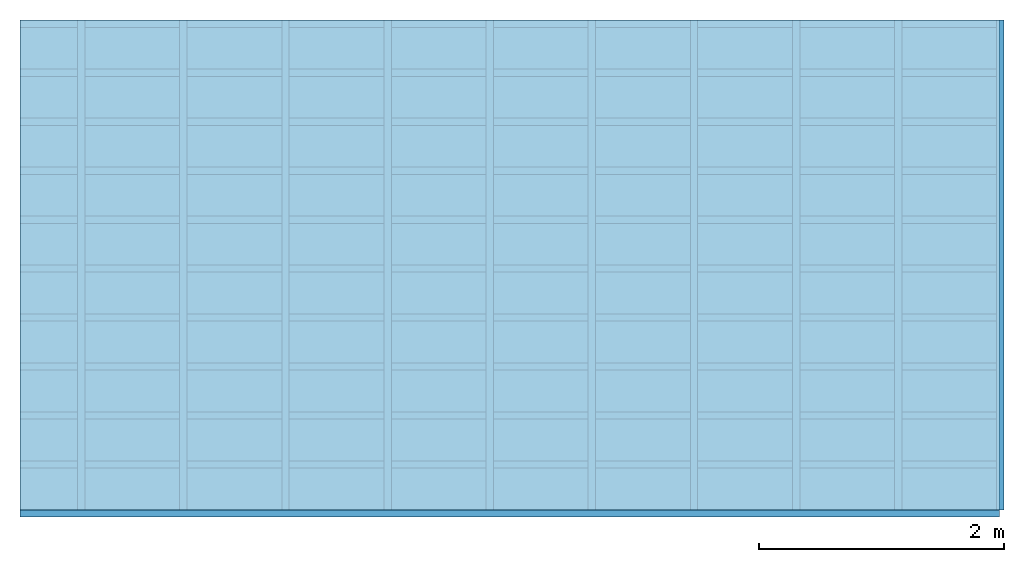
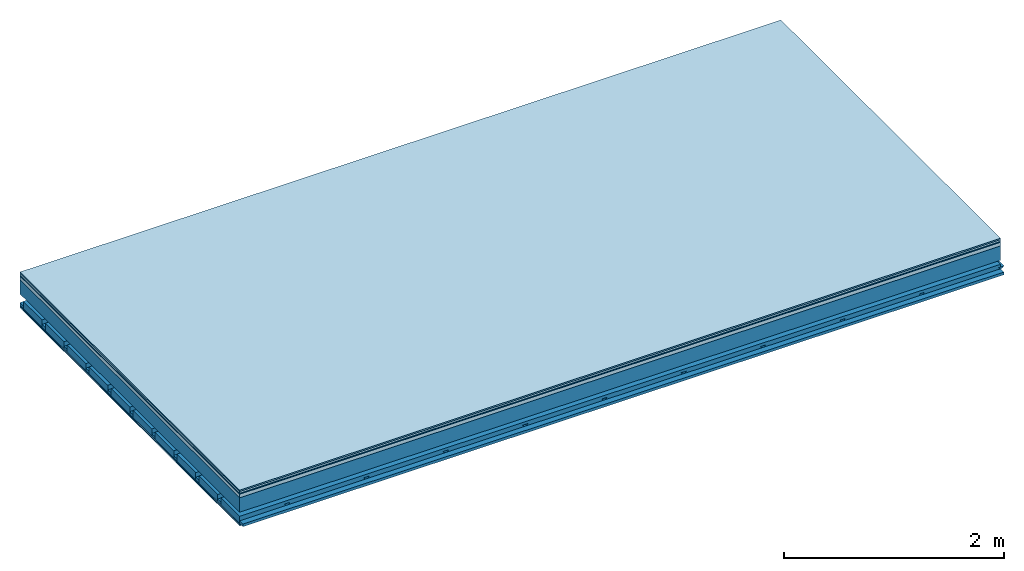
# One storey: 7 plates, 4 members, 1 element without a shape of its own.
"""IFC4 building model written with IfcOpenShell, lengths in metres."""

from ifc_helpers import new_model, si_unit, derived_unit, direction, frame, frame_2d, origin, origin_with_axes, place, context, project, spatial, polyline, rectangle, outline, extrude, material, layer, layer_set, type_object, element, aggregate, save


model = new_model("IFC4")

# Units and contexts
plan_context = context("Plan", 3, precision=1e-05, world=origin(), true_north=direction((0.0, 1.0)))
model_context = context("Model", 3, precision=1e-05, world=origin(), true_north=direction((0.0, 1.0)))
ifc_project = project(units=[si_unit("LENGTHUNIT", "METRE"), derived_unit("SOUNDPRESSUREUNIT", [(si_unit("PRESSUREUNIT", "PASCAL", prefix="MICRO"), 0)]), si_unit("ENERGYUNIT", "JOULE", prefix="MEGA"), si_unit("MASSUNIT", "GRAM", prefix="KILO"), derived_unit("THERMALTRANSMITTANCEUNIT", [(si_unit("POWERUNIT", "WATT"), 1), (si_unit("AREAUNIT", "SQUARE_METRE"), -1), (si_unit("THERMODYNAMICTEMPERATUREUNIT", "KELVIN"), -1)]), derived_unit("AREADENSITYUNIT", [(si_unit("MASSUNIT", "GRAM", prefix="KILO"), 1), (si_unit("AREAUNIT", "SQUARE_METRE"), -1)]), derived_unit("USERDEFINED", [(si_unit("ENERGYUNIT", "JOULE", prefix="MEGA"), 1), (si_unit("AREAUNIT", "SQUARE_METRE"), -1)])], contexts=[plan_context, model_context])

# Site, building, storey
site = spatial("IfcSite", under=ifc_project)
building_placement = place(None, origin())
building = spatial("IfcBuilding", under=site, at=building_placement)
storey_placement = place(building_placement, origin())
storey = spatial("IfcBuildingStorey", under=building, at=storey_placement)

# Slab, members, plates
ifc_material_1 = material(Category="11.013")
ifc_layer_1 = layer(ifc_material_1, 0.015, Name="Flooring")
ifc_material_2 = material(Category="03.007")
ifc_layer_2 = layer(ifc_material_2, 0.02, Name="On-material")
ifc_material_3 = material(Name="Wood fiber generic product", Category="10.009")
ifc_layer_3 = layer(ifc_material_3, 0.01, Name="Impact sound insulation")
ifc_material_4 = material(Name="Concrete panels", Category="02.007")
ifc_layer_4 = layer(ifc_material_4, 0.04, Name="on Supporting structure")
ifc_material_5 = material(Name="no composite action")
ifc_layer_5 = layer(ifc_material_5, 0.0, Name="Bond")
ifc_layer_6 = layer(None, 0.16, Name="Supporting structure")
ifc_layer_7 = layer(ifc_material_5, 0.0, Name="Bond")
ifc_layer_8 = layer(None, 0.095, Name="Coupling")
ifc_layer_9 = layer(None, 0.03, Name="Battens / profiles")
ifc_material_6 = material(Name="Plasterboard type A", Category="03.008")
ifc_layer_10 = layer(ifc_material_6, 0.0125, Name="Ceiling covering 1st layer")
ifc_layer_11 = layer(ifc_material_6, 0.0125, Name="Ceiling covering layer 2")
ifc_material_7 = material(Category="04.001")
ifc_layer_12 = layer(ifc_material_7, 0.003, Name="Surface / treatment")
ifc_layer_set = layer_set([ifc_layer_1, ifc_layer_2, ifc_layer_3, ifc_layer_4, ifc_layer_5, ifc_layer_6, ifc_layer_7, ifc_layer_8, ifc_layer_9, ifc_layer_10, ifc_layer_11, ifc_layer_12])
slab_type = type_object("IfcSlabType", Name="A2134", PredefinedType="NOTDEFINED", material=ifc_layer_set)
slab_placement = place(None, frame((0.0, 0.0, 0.0), z_axis=(0.0, 0.0, -1.0), x_axis=(1.0, 0.0, 0.0)))
slab = element("IfcSlab", 1, at=slab_placement, inside=storey, type_object=slab_type, material=ifc_layer_set, Name="Slab #1")
ifc_material_8 = material(Name="Solid timber panel")
member_1_placement = place(slab_placement, origin())
member_1 = element("IfcMember", 2, at=member_1_placement, material=ifc_material_8, Name="Supporting structure", context=plan_context, shape_type="SweptSolid", body=[
    extrude(rectangle(XDim=1.0, YDim=0.16, at=frame_2d((0.5, 0.08), x_axis=(1.0, 0.0))), frame((0.0, 4.0, 0.085), z_axis=(0.0, -1.0, 0.0), x_axis=(1.0, 0.0, 0.0)), (0.0, 0.0, 1.0), 4.0),
    extrude(rectangle(XDim=1.0, YDim=0.16, at=frame_2d((0.5, 0.08), x_axis=(1.0, 0.0))), frame((1.0, 4.0, 0.085), z_axis=(0.0, -1.0, 0.0), x_axis=(1.0, 0.0, 0.0)), (0.0, 0.0, 1.0), 4.0),
    extrude(rectangle(XDim=1.0, YDim=0.16, at=frame_2d((0.5, 0.08), x_axis=(1.0, 0.0))), frame((2.0, 4.0, 0.085), z_axis=(0.0, -1.0, 0.0), x_axis=(1.0, 0.0, 0.0)), (0.0, 0.0, 1.0), 4.0),
    extrude(rectangle(XDim=1.0, YDim=0.16, at=frame_2d((0.5, 0.08), x_axis=(1.0, 0.0))), frame((3.0, 4.0, 0.085), z_axis=(0.0, -1.0, 0.0), x_axis=(1.0, 0.0, 0.0)), (0.0, 0.0, 1.0), 4.0),
    extrude(rectangle(XDim=1.0, YDim=0.16, at=frame_2d((0.5, 0.08), x_axis=(1.0, 0.0))), frame((4.0, 4.0, 0.085), z_axis=(0.0, -1.0, 0.0), x_axis=(1.0, 0.0, 0.0)), (0.0, 0.0, 1.0), 4.0),
    extrude(rectangle(XDim=1.0, YDim=0.16, at=frame_2d((0.5, 0.08), x_axis=(1.0, 0.0))), frame((5.0, 4.0, 0.085), z_axis=(0.0, -1.0, 0.0), x_axis=(1.0, 0.0, 0.0)), (0.0, 0.0, 1.0), 4.0),
    extrude(rectangle(XDim=1.0, YDim=0.16, at=frame_2d((0.5, 0.08), x_axis=(1.0, 0.0))), frame((6.0, 4.0, 0.085), z_axis=(0.0, -1.0, 0.0), x_axis=(1.0, 0.0, 0.0)), (0.0, 0.0, 1.0), 4.0),
    extrude(rectangle(XDim=1.0, YDim=0.16, at=frame_2d((0.5, 0.08), x_axis=(1.0, 0.0))), frame((7.0, 4.0, 0.085), z_axis=(0.0, -1.0, 0.0), x_axis=(1.0, 0.0, 0.0)), (0.0, 0.0, 1.0), 4.0),
])
ifc_material_9 = material()
member_2_placement = place(slab_placement, origin())
member_2 = element("IfcMember", 3, at=member_2_placement, material=ifc_material_9, Name="Coupling", context=plan_context, shape_type="SweptSolid", body=[
    extrude(outline(polyline([(0.0, 0.0), (0.06, 0.0), (0.04, 0.02), (0.02, 0.02), (0.0, 0.0)])), frame((0.47, 4.0, 0.32), z_axis=(0.0, -1.0, 0.0), x_axis=(1.0, 0.0, 0.0)), (0.0, 0.0, 1.0), 4.0),
    extrude(outline(polyline([(0.0, 0.0), (0.06, 0.0), (0.04, 0.02), (0.02, 0.02), (0.0, 0.0)])), frame((1.304, 4.0, 0.32), z_axis=(0.0, -1.0, 0.0), x_axis=(1.0, 0.0, 0.0)), (0.0, 0.0, 1.0), 4.0),
    extrude(outline(polyline([(0.0, 0.0), (0.06, 0.0), (0.04, 0.02), (0.02, 0.02), (0.0, 0.0)])), frame((2.138, 4.0, 0.32), z_axis=(0.0, -1.0, 0.0), x_axis=(1.0, 0.0, 0.0)), (0.0, 0.0, 1.0), 4.0),
    extrude(outline(polyline([(0.0, 0.0), (0.06, 0.0), (0.04, 0.02), (0.02, 0.02), (0.0, 0.0)])), frame((2.972, 4.0, 0.32), z_axis=(0.0, -1.0, 0.0), x_axis=(1.0, 0.0, 0.0)), (0.0, 0.0, 1.0), 4.0),
    extrude(outline(polyline([(0.0, 0.0), (0.06, 0.0), (0.04, 0.02), (0.02, 0.02), (0.0, 0.0)])), frame((3.806, 4.0, 0.32), z_axis=(0.0, -1.0, 0.0), x_axis=(1.0, 0.0, 0.0)), (0.0, 0.0, 1.0), 4.0),
    extrude(outline(polyline([(0.0, 0.0), (0.06, 0.0), (0.04, 0.02), (0.02, 0.02), (0.0, 0.0)])), frame((4.64, 4.0, 0.32), z_axis=(0.0, -1.0, 0.0), x_axis=(1.0, 0.0, 0.0)), (0.0, 0.0, 1.0), 4.0),
    extrude(outline(polyline([(0.0, 0.0), (0.06, 0.0), (0.04, 0.02), (0.02, 0.02), (0.0, 0.0)])), frame((5.474, 4.0, 0.32), z_axis=(0.0, -1.0, 0.0), x_axis=(1.0, 0.0, 0.0)), (0.0, 0.0, 1.0), 4.0),
    extrude(outline(polyline([(0.0, 0.0), (0.06, 0.0), (0.04, 0.02), (0.02, 0.02), (0.0, 0.0)])), frame((6.308, 4.0, 0.32), z_axis=(0.0, -1.0, 0.0), x_axis=(1.0, 0.0, 0.0)), (0.0, 0.0, 1.0), 4.0),
    extrude(outline(polyline([(0.0, 0.0), (0.06, 0.0), (0.04, 0.02), (0.02, 0.02), (0.0, 0.0)])), frame((7.142, 4.0, 0.32), z_axis=(0.0, -1.0, 0.0), x_axis=(1.0, 0.0, 0.0)), (0.0, 0.0, 1.0), 4.0),
    extrude(outline(polyline([(0.0, 0.0), (0.06, 0.0), (0.04, 0.02), (0.02, 0.02), (0.0, 0.0)])), frame((7.976, 4.0, 0.32), z_axis=(0.0, -1.0, 0.0), x_axis=(1.0, 0.0, 0.0)), (0.0, 0.0, 1.0), 4.0),
])
member_3_placement = place(slab_placement, origin())
member_3 = element("IfcMember", 4, at=member_3_placement, material=ifc_material_9, Name="Battens / profiles", context=plan_context, shape_type="SweptSolid", body=[
    extrude(rectangle(XDim=0.06, YDim=0.03, at=frame_2d((0.03, 0.015), x_axis=(1.0, 0.0))), frame((0.0, 0.0, 0.34), z_axis=(1.0, 0.0, 0.0), x_axis=(0.0, 1.0, 0.0)), (0.0, 0.0, 1.0), 8.0),
    extrude(rectangle(XDim=0.06, YDim=0.03, at=frame_2d((0.03, 0.015), x_axis=(1.0, 0.0))), frame((0.0, 0.4, 0.34), z_axis=(1.0, 0.0, 0.0), x_axis=(0.0, 1.0, 0.0)), (0.0, 0.0, 1.0), 8.0),
    extrude(rectangle(XDim=0.06, YDim=0.03, at=frame_2d((0.03, 0.015), x_axis=(1.0, 0.0))), frame((0.0, 0.8, 0.34), z_axis=(1.0, 0.0, 0.0), x_axis=(0.0, 1.0, 0.0)), (0.0, 0.0, 1.0), 8.0),
    extrude(rectangle(XDim=0.06, YDim=0.03, at=frame_2d((0.03, 0.015), x_axis=(1.0, 0.0))), frame((0.0, 1.2, 0.34), z_axis=(1.0, 0.0, 0.0), x_axis=(0.0, 1.0, 0.0)), (0.0, 0.0, 1.0), 8.0),
    extrude(rectangle(XDim=0.06, YDim=0.03, at=frame_2d((0.03, 0.015), x_axis=(1.0, 0.0))), frame((0.0, 1.6, 0.34), z_axis=(1.0, 0.0, 0.0), x_axis=(0.0, 1.0, 0.0)), (0.0, 0.0, 1.0), 8.0),
    extrude(rectangle(XDim=0.06, YDim=0.03, at=frame_2d((0.03, 0.015), x_axis=(1.0, 0.0))), frame((0.0, 2.0, 0.34), z_axis=(1.0, 0.0, 0.0), x_axis=(0.0, 1.0, 0.0)), (0.0, 0.0, 1.0), 8.0),
    extrude(rectangle(XDim=0.06, YDim=0.03, at=frame_2d((0.03, 0.015), x_axis=(1.0, 0.0))), frame((0.0, 2.4, 0.34), z_axis=(1.0, 0.0, 0.0), x_axis=(0.0, 1.0, 0.0)), (0.0, 0.0, 1.0), 8.0),
    extrude(rectangle(XDim=0.06, YDim=0.03, at=frame_2d((0.03, 0.015), x_axis=(1.0, 0.0))), frame((0.0, 2.8, 0.34), z_axis=(1.0, 0.0, 0.0), x_axis=(0.0, 1.0, 0.0)), (0.0, 0.0, 1.0), 8.0),
    extrude(rectangle(XDim=0.06, YDim=0.03, at=frame_2d((0.03, 0.015), x_axis=(1.0, 0.0))), frame((0.0, 3.2, 0.34), z_axis=(1.0, 0.0, 0.0), x_axis=(0.0, 1.0, 0.0)), (0.0, 0.0, 1.0), 8.0),
    extrude(rectangle(XDim=0.06, YDim=0.03, at=frame_2d((0.03, 0.015), x_axis=(1.0, 0.0))), frame((0.0, 3.6, 0.34), z_axis=(1.0, 0.0, 0.0), x_axis=(0.0, 1.0, 0.0)), (0.0, 0.0, 1.0), 8.0),
    extrude(rectangle(XDim=0.06, YDim=0.03, at=frame_2d((0.03, 0.015), x_axis=(1.0, 0.0))), frame((0.0, 4.0, 0.34), z_axis=(1.0, 0.0, 0.0), x_axis=(0.0, 1.0, 0.0)), (0.0, 0.0, 1.0), 8.0),
])
ifc_material_10 = material()
member_4_placement = place(slab_placement, origin())
member_4 = element("IfcMember", 5, at=member_4_placement, material=ifc_material_10, Name="Cavity", context=plan_context, shape_type="SweptSolid", body=[
    extrude(rectangle(XDim=0.34, YDim=0.08, at=frame_2d((0.17, 0.04), x_axis=(1.0, 0.0))), frame((0.0, 0.06, 0.29), z_axis=(1.0, 0.0, 0.0), x_axis=(0.0, 1.0, 0.0)), (0.0, 0.0, 1.0), 8.0),
    extrude(rectangle(XDim=0.34, YDim=0.08, at=frame_2d((0.17, 0.04), x_axis=(1.0, 0.0))), frame((0.0, 0.46, 0.29), z_axis=(1.0, 0.0, 0.0), x_axis=(0.0, 1.0, 0.0)), (0.0, 0.0, 1.0), 8.0),
    extrude(rectangle(XDim=0.34, YDim=0.08, at=frame_2d((0.17, 0.04), x_axis=(1.0, 0.0))), frame((0.0, 0.86, 0.29), z_axis=(1.0, 0.0, 0.0), x_axis=(0.0, 1.0, 0.0)), (0.0, 0.0, 1.0), 8.0),
    extrude(rectangle(XDim=0.34, YDim=0.08, at=frame_2d((0.17, 0.04), x_axis=(1.0, 0.0))), frame((0.0, 1.26, 0.29), z_axis=(1.0, 0.0, 0.0), x_axis=(0.0, 1.0, 0.0)), (0.0, 0.0, 1.0), 8.0),
    extrude(rectangle(XDim=0.34, YDim=0.08, at=frame_2d((0.17, 0.04), x_axis=(1.0, 0.0))), frame((0.0, 1.66, 0.29), z_axis=(1.0, 0.0, 0.0), x_axis=(0.0, 1.0, 0.0)), (0.0, 0.0, 1.0), 8.0),
    extrude(rectangle(XDim=0.34, YDim=0.08, at=frame_2d((0.17, 0.04), x_axis=(1.0, 0.0))), frame((0.0, 2.06, 0.29), z_axis=(1.0, 0.0, 0.0), x_axis=(0.0, 1.0, 0.0)), (0.0, 0.0, 1.0), 8.0),
    extrude(rectangle(XDim=0.34, YDim=0.08, at=frame_2d((0.17, 0.04), x_axis=(1.0, 0.0))), frame((0.0, 2.46, 0.29), z_axis=(1.0, 0.0, 0.0), x_axis=(0.0, 1.0, 0.0)), (0.0, 0.0, 1.0), 8.0),
    extrude(rectangle(XDim=0.34, YDim=0.08, at=frame_2d((0.17, 0.04), x_axis=(1.0, 0.0))), frame((0.0, 2.86, 0.29), z_axis=(1.0, 0.0, 0.0), x_axis=(0.0, 1.0, 0.0)), (0.0, 0.0, 1.0), 8.0),
    extrude(rectangle(XDim=0.34, YDim=0.08, at=frame_2d((0.17, 0.04), x_axis=(1.0, 0.0))), frame((0.0, 3.26, 0.29), z_axis=(1.0, 0.0, 0.0), x_axis=(0.0, 1.0, 0.0)), (0.0, 0.0, 1.0), 8.0),
    extrude(rectangle(XDim=0.34, YDim=0.08, at=frame_2d((0.17, 0.04), x_axis=(1.0, 0.0))), frame((0.0, 3.66, 0.29), z_axis=(1.0, 0.0, 0.0), x_axis=(0.0, 1.0, 0.0)), (0.0, 0.0, 1.0), 8.0),
])
plate_1_placement = place(slab_placement, origin())
plate_1 = element("IfcPlate", 6, at=plate_1_placement, material=ifc_material_1, Name="Flooring", context=plan_context, shape_type="SweptSolid", body=[
    extrude(rectangle(XDim=8.0, YDim=4.0, at=frame_2d((4.0, 2.0), x_axis=(1.0, 0.0))), origin_with_axes(), (0.0, 0.0, 1.0), 0.015),
])
plate_2_placement = place(slab_placement, origin())
plate_2 = element("IfcPlate", 7, at=plate_2_placement, material=ifc_material_2, Name="On-material", context=plan_context, shape_type="SweptSolid", body=[
    extrude(rectangle(XDim=8.0, YDim=4.0, at=frame_2d((4.0, 2.0), x_axis=(1.0, 0.0))), frame((0.0, 0.0, 0.015), z_axis=(0.0, 0.0, 1.0), x_axis=(1.0, 0.0, 0.0)), (0.0, 0.0, 1.0), 0.02),
])
plate_3_placement = place(slab_placement, origin())
plate_3 = element("IfcPlate", 8, at=plate_3_placement, material=ifc_material_3, Name="Impact sound insulation", context=plan_context, shape_type="SweptSolid", body=[
    extrude(rectangle(XDim=8.0, YDim=4.0, at=frame_2d((4.0, 2.0), x_axis=(1.0, 0.0))), frame((0.0, 0.0, 0.035), z_axis=(0.0, 0.0, 1.0), x_axis=(1.0, 0.0, 0.0)), (0.0, 0.0, 1.0), 0.01),
])
plate_4_placement = place(slab_placement, origin())
plate_4 = element("IfcPlate", 9, at=plate_4_placement, material=ifc_material_4, Name="on Supporting structure", context=plan_context, shape_type="SweptSolid", body=[
    extrude(rectangle(XDim=8.0, YDim=4.0, at=frame_2d((4.0, 2.0), x_axis=(1.0, 0.0))), frame((0.0, 0.0, 0.045), z_axis=(0.0, 0.0, 1.0), x_axis=(1.0, 0.0, 0.0)), (0.0, 0.0, 1.0), 0.04),
])
plate_5_placement = place(slab_placement, origin())
plate_5 = element("IfcPlate", 10, at=plate_5_placement, material=ifc_material_6, Name="Ceiling covering 1st layer", context=plan_context, shape_type="SweptSolid", body=[
    extrude(rectangle(XDim=8.0, YDim=4.0, at=frame_2d((4.0, 2.0), x_axis=(1.0, 0.0))), frame((0.0, 0.0, 0.37), z_axis=(0.0, 0.0, 1.0), x_axis=(1.0, 0.0, 0.0)), (0.0, 0.0, 1.0), 0.0125),
])
plate_6_placement = place(slab_placement, origin())
plate_6 = element("IfcPlate", 11, at=plate_6_placement, material=ifc_material_6, Name="Ceiling covering layer 2", context=plan_context, shape_type="SweptSolid", body=[
    extrude(rectangle(XDim=8.0, YDim=4.0, at=frame_2d((4.0, 2.0), x_axis=(1.0, 0.0))), frame((0.0, 0.0, 0.3825), z_axis=(0.0, 0.0, 1.0), x_axis=(1.0, 0.0, 0.0)), (0.0, 0.0, 1.0), 0.0125),
])
plate_7_placement = place(slab_placement, origin())
plate_7 = element("IfcPlate", 12, at=plate_7_placement, material=ifc_material_7, Name="Surface / treatment", context=plan_context, shape_type="SweptSolid", body=[
    extrude(rectangle(XDim=8.0, YDim=4.0, at=frame_2d((4.0, 2.0), x_axis=(1.0, 0.0))), frame((0.0, 0.0, 0.395), z_axis=(0.0, 0.0, 1.0), x_axis=(1.0, 0.0, 0.0)), (0.0, 0.0, 1.0), 0.003),
])
aggregate(slab, [plate_1, plate_2, plate_3, plate_4, member_1, member_2, member_3, member_4, plate_5, plate_6, plate_7])

save(model, "model.ifc")
